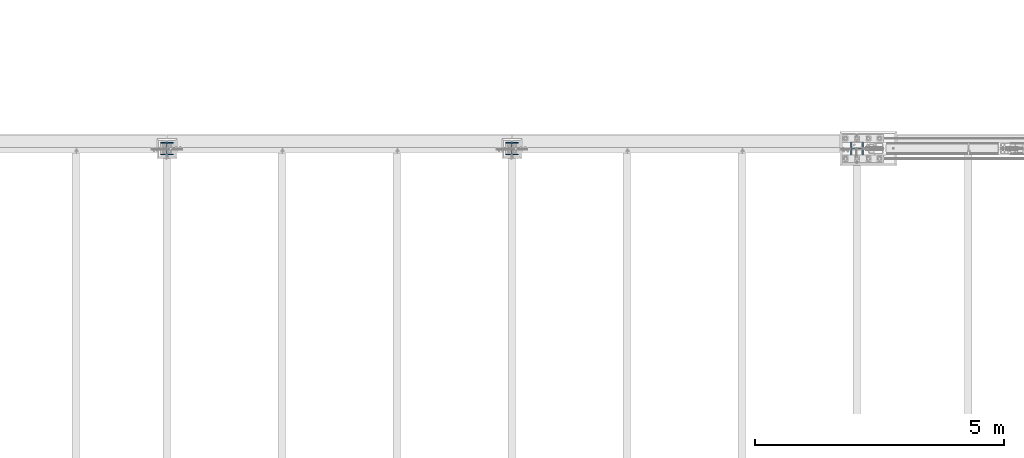
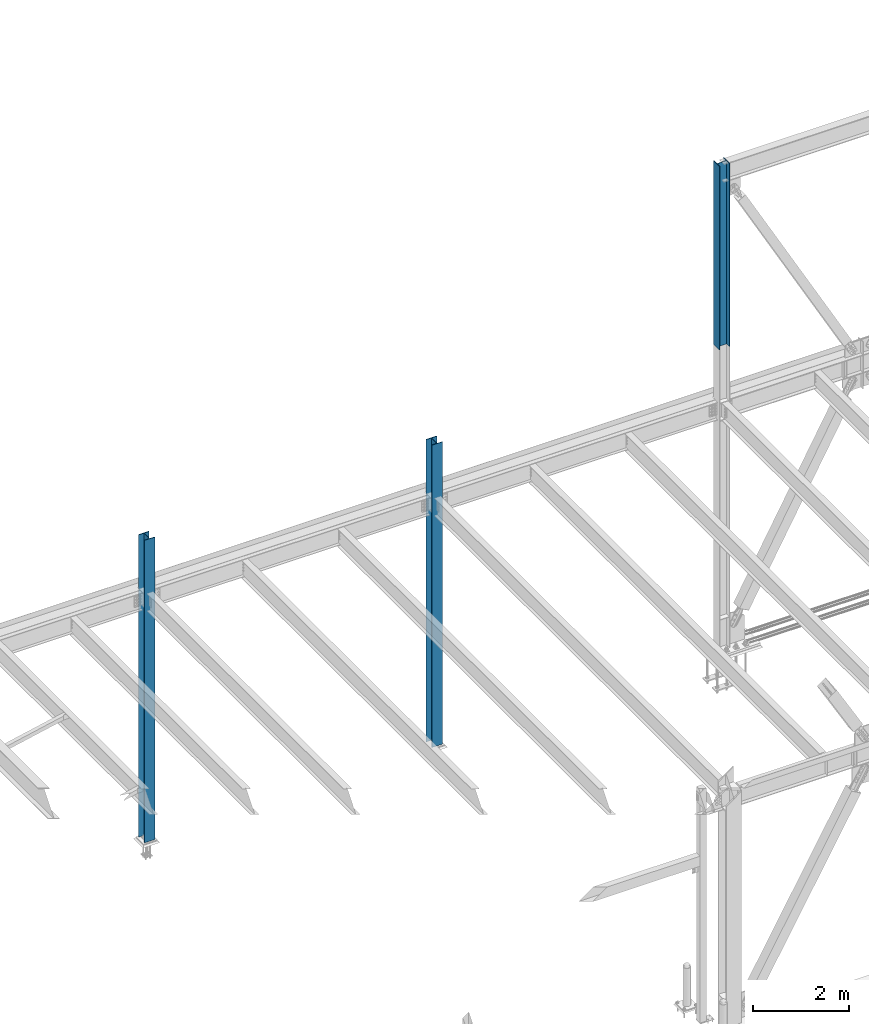
# One storey, part 1397 of 3843: 3 columns, 3 elements without a shape of their own.
"""IFC2X3 building model written with IfcOpenShell, lengths in millimetres."""

from ifc_helpers import new_model, si_unit, frame, origin_with_axes, place, context, subcontext, project, spatial, faceted_brep, material, type_object, element, aggregate, save


model = new_model("IFC2X3")

# Units and contexts
model_context = context("Model", 3, precision=1e-05, world=origin_with_axes())
body_context = subcontext(model_context, "Body", "Model", "MODEL_VIEW")
ifc_project = project(units=[si_unit("LENGTHUNIT", "METRE", prefix="MILLI"), si_unit("AREAUNIT", "SQUARE_METRE"), si_unit("VOLUMEUNIT", "CUBIC_METRE"), si_unit("MASSUNIT", "GRAM", prefix="KILO"), si_unit("TIMEUNIT", "SECOND"), si_unit("PLANEANGLEUNIT", "RADIAN"), si_unit("SOLIDANGLEUNIT", "STERADIAN"), si_unit("THERMODYNAMICTEMPERATUREUNIT", "DEGREE_CELSIUS"), si_unit("LUMINOUSINTENSITYUNIT", "LUMEN")], contexts=[model_context])

# Site, building, storey
site_placement = place(None, origin_with_axes())
site = spatial("IfcSite", under=ifc_project, at=site_placement, CompositionType="ELEMENT")
building_placement = place(site_placement, origin_with_axes())
building = spatial("IfcBuilding", under=site, at=building_placement, Name="Undefined", CompositionType="ELEMENT")
storey_placement = place(building_placement, origin_with_axes())
storey = spatial("IfcBuildingStorey", under=building, at=storey_placement, Name="Undefined", CompositionType="ELEMENT", Elevation=0.0)

# Assembly, column
assembly_1_placement = place(storey_placement, origin_with_axes())
assembly_1 = element("IfcElementAssembly", 1, at=assembly_1_placement, inside=storey, Name="CB", AssemblyPlace="NOTDEFINED", PredefinedType="RIGID_FRAME")
ifc_material = material(Name="STEEL/A992")
column_type_1 = type_object("IfcColumnType", Name="W10X60", PredefinedType="NOTDEFINED")
column_1_placement = place(assembly_1_placement, frame((55930.8, 104559.1, 37795.2), z_axis=(-1.0, 0.0, 0.0), x_axis=(0.0, 0.0, 1.0)))
column_1 = element("IfcColumn", 2, at=column_1_placement, type_object=column_type_1, material=ifc_material, Name="COLUMN", ObjectType="W10X60", context=body_context, shape_type="Brep", body=[
    faceted_brep([(0.0, 128.587499999994, -130.174999999999), (0.0, 128.587499999994, -112.712500000001), (4673.60000000001, 128.587499999994, -112.712500000001), (4673.60000000001, 128.587499999994, -130.174999999999), (0.0, 5.55624999999418, -112.712500000001), (4673.60000000001, 5.55624999999418, -112.712500000001), (0.0, 5.55624999999418, 112.712500000001), (4673.60000000001, 5.55624999999418, 112.712500000001), (0.0, 128.587499999994, 112.712500000001), (4673.60000000001, 128.587499999994, 112.712500000001), (0.0, 128.587499999994, 130.174999999999), (4673.60000000001, 128.587499999994, 130.174999999999), (0.0, -128.587499999994, 130.174999999999), (4673.60000000001, -128.587499999994, 130.174999999999), (0.0, -128.587499999994, 112.712500000001), (4673.60000000001, -128.587499999994, 112.712500000001), (0.0, -5.55624999999418, 112.712500000001), (4673.60000000001, -5.55624999999418, 112.712500000001), (0.0, -5.55624999999418, -112.712500000001), (4673.60000000001, -5.55624999999418, -112.712500000001), (0.0, -128.587499999994, -112.712500000001), (4673.60000000001, -128.587499999994, -112.712500000001), (0.0, -128.587499999994, -130.174999999999), (4673.60000000001, -128.587499999994, -130.174999999999)], [[[0, 1, 2, 3]], [[1, 4, 5, 2]], [[4, 6, 7, 5]], [[6, 8, 9, 7]], [[8, 10, 11, 9]], [[10, 12, 13, 11]], [[12, 14, 15, 13]], [[14, 16, 17, 15]], [[16, 18, 19, 17]], [[18, 20, 21, 19]], [[20, 22, 23, 21]], [[22, 0, 3, 23]], [[5, 7, 9, 11, 13, 15, 17, 19, 21, 23, 3, 2]], [[22, 20, 18, 16, 14, 12, 10, 8, 6, 4, 1, 0]]]),
])
aggregate(assembly_1, [column_1])

assembly_2_placement = place(storey_placement, origin_with_axes())
assembly_2 = element("IfcElementAssembly", 3, at=assembly_2_placement, inside=storey, Name="COLUMN", AssemblyPlace="NOTDEFINED", PredefinedType="RIGID_FRAME")
column_type_2 = type_object("IfcColumnType", Name="W10X49", PredefinedType="NOTDEFINED")
column_2_placement = place(assembly_2_placement, frame((48996.6, 104559.1, 30022.8), z_axis=(0.0, 1.0, 0.0), x_axis=(0.0, 0.0, 1.0)))
column_2 = element("IfcColumn", 4, at=column_2_placement, type_object=column_type_2, material=ifc_material, Name="COLUMN", ObjectType="W10X49", context=body_context, shape_type="Brep", body=[
    faceted_brep([(63.4999999999964, 127.0, -127.0), (63.4999999999964, 127.0, -112.712499999994), (7772.4, 127.0, -112.712499999994), (7772.4, 127.0, -127.0), (63.4999999999964, 3.96875, -112.7125), (7772.4, 3.96875, -112.712499999994), (63.4999999999964, 3.96875, 112.7125), (7772.4, 3.96875, 112.712499999994), (63.4999999999964, 127.0, 112.712499999994), (7772.4, 127.0, 112.712499999994), (63.4999999999964, 127.0, 127.0), (7772.4, 127.0, 127.0), (63.4999999999964, -127.0, 127.0), (7772.4, -127.0, 127.0), (63.4999999999964, -127.0, 112.712499999994), (7772.4, -127.0, 112.712499999994), (63.4999999999964, -3.96875, 112.7125), (7772.4, -3.96875, 112.712499999994), (63.4999999999964, -3.96875, -112.7125), (7772.4, -3.96875, -112.712499999994), (63.4999999999964, -127.0, -112.712499999994), (7772.4, -127.0, -112.712499999994), (63.4999999999964, -127.0, -127.0), (7772.4, -127.0, -127.0)], [[[0, 1, 2, 3]], [[1, 4, 5, 2]], [[4, 6, 7, 5]], [[6, 8, 9, 7]], [[8, 10, 11, 9]], [[10, 12, 13, 11]], [[12, 14, 15, 13]], [[14, 16, 17, 15]], [[16, 18, 19, 17]], [[18, 20, 21, 19]], [[20, 22, 23, 21]], [[22, 0, 3, 23]], [[5, 7, 9, 11, 13, 15, 17, 19, 21, 23, 3, 2]], [[22, 20, 18, 16, 14, 12, 10, 8, 6, 4, 1, 0]]]),
])
aggregate(assembly_2, [column_2])

assembly_3_placement = place(storey_placement, origin_with_axes())
assembly_3 = element("IfcElementAssembly", 5, at=assembly_3_placement, inside=storey, Name="COLUMN", AssemblyPlace="NOTDEFINED", PredefinedType="RIGID_FRAME")
column_3_placement = place(assembly_3_placement, frame((42062.4, 104559.1, 30022.8), z_axis=(0.0, 1.0, 0.0), x_axis=(0.0, 0.0, 1.0)))
column_3 = element("IfcColumn", 6, at=column_3_placement, type_object=column_type_2, material=ifc_material, Name="COLUMN", ObjectType="W10X49", context=body_context, shape_type="Brep", body=[
    faceted_brep([(63.4999999999964, 127.0, -127.0), (63.4999999999964, 127.0, -112.712499999994), (7772.4, 127.0, -112.712499999994), (7772.4, 127.0, -127.0), (63.4999999999964, 3.96875, -112.7125), (7772.4, 3.96875, -112.712499999994), (63.4999999999964, 3.96875, 112.7125), (7772.4, 3.96875, 112.712499999994), (63.4999999999964, 127.0, 112.712499999994), (7772.4, 127.0, 112.712499999994), (63.4999999999964, 127.0, 127.0), (7772.4, 127.0, 127.0), (63.4999999999964, -127.0, 127.0), (7772.4, -127.0, 127.0), (63.4999999999964, -127.0, 112.712499999994), (7772.4, -127.0, 112.712499999994), (63.4999999999964, -3.96875, 112.7125), (7772.4, -3.96875, 112.712499999994), (63.4999999999964, -3.96875, -112.7125), (7772.4, -3.96875, -112.712499999994), (63.4999999999964, -127.0, -112.712499999994), (7772.4, -127.0, -112.712499999994), (63.4999999999964, -127.0, -127.0), (7772.4, -127.0, -127.0)], [[[0, 1, 2, 3]], [[1, 4, 5, 2]], [[4, 6, 7, 5]], [[6, 8, 9, 7]], [[8, 10, 11, 9]], [[10, 12, 13, 11]], [[12, 14, 15, 13]], [[14, 16, 17, 15]], [[16, 18, 19, 17]], [[18, 20, 21, 19]], [[20, 22, 23, 21]], [[22, 0, 3, 23]], [[5, 7, 9, 11, 13, 15, 17, 19, 21, 23, 3, 2]], [[22, 20, 18, 16, 14, 12, 10, 8, 6, 4, 1, 0]]]),
])
aggregate(assembly_3, [column_3])

save(model, "model.ifc")
